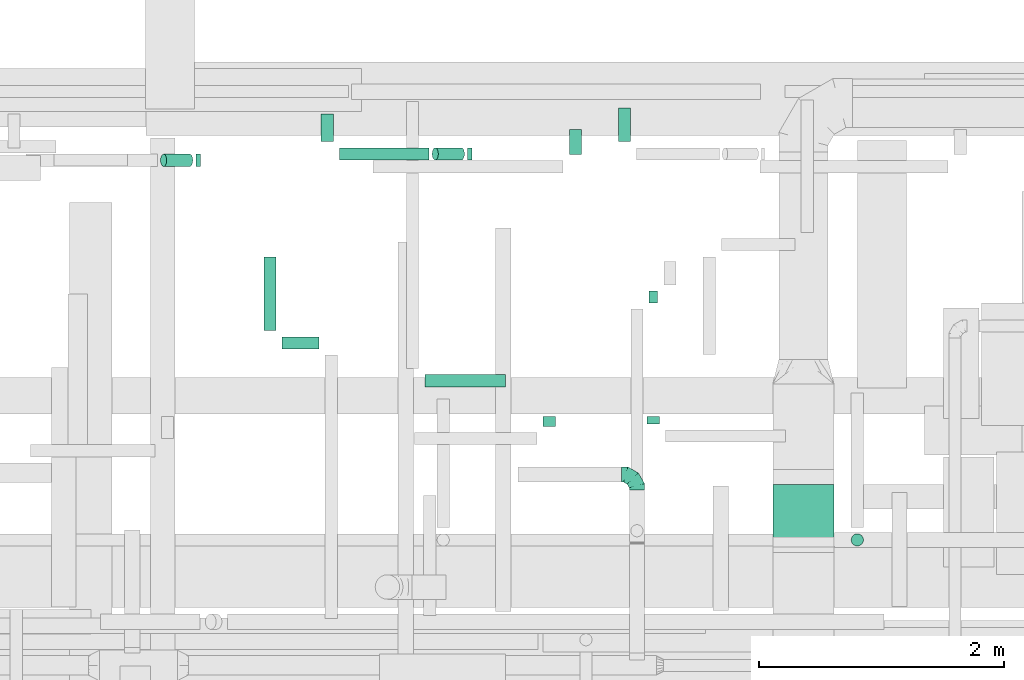
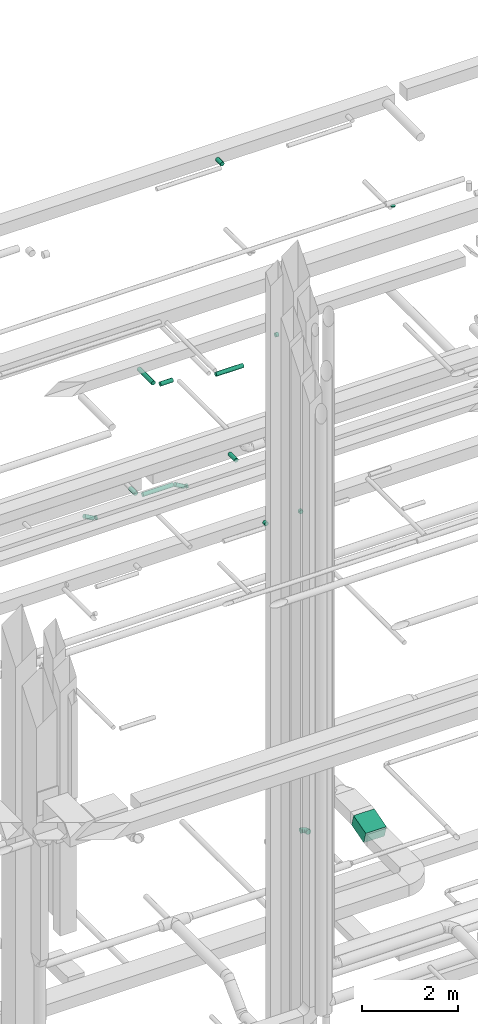
# One storey, part 156 of 337: 16 flow segments, 1 flow fitting.
"""IFC2X3 building model written with IfcOpenShell, lengths in millimetres."""

from ifc_helpers import new_model, entity, si_unit, converted_unit, derived_unit, direction, frame, frame_2d, origin, origin_2d_with_axis, place, context, subcontext, project, spatial, rectangle, circle, extrude, faceted_brep, source, transform, mapped, material, type_object, type_shapes, element, save


model = new_model("IFC2X3")

# Units and contexts
model_context = context("Model", 3, precision=0.01, world=origin(), true_north=direction((6.12303176911189e-17, 1.0)))
body_context = subcontext(model_context, "Body", "Model", "MODEL_VIEW")
ifc_project = project(units=[si_unit("LENGTHUNIT", "METRE", prefix="MILLI"), si_unit("AREAUNIT", "SQUARE_METRE"), si_unit("VOLUMEUNIT", "CUBIC_METRE"), converted_unit("PLANEANGLEUNIT", "DEGREE", entity("IfcRatioMeasure", 0.0174532925199433), si_unit("PLANEANGLEUNIT", "RADIAN"), dimensions=[0, 0, 0, 0, 0, 0, 0]), si_unit("MASSUNIT", "GRAM", prefix="KILO"), derived_unit("MASSDENSITYUNIT", [(si_unit("MASSUNIT", "GRAM", prefix="KILO"), 1), (si_unit("LENGTHUNIT", "METRE"), -3)]), derived_unit("MOMENTOFINERTIAUNIT", [(si_unit("LENGTHUNIT", "METRE"), 4)]), si_unit("TIMEUNIT", "SECOND"), si_unit("FREQUENCYUNIT", "HERTZ"), si_unit("THERMODYNAMICTEMPERATUREUNIT", "DEGREE_CELSIUS"), derived_unit("THERMALTRANSMITTANCEUNIT", [(si_unit("MASSUNIT", "GRAM", prefix="KILO"), 1), (si_unit("THERMODYNAMICTEMPERATUREUNIT", "KELVIN"), -1), (si_unit("TIMEUNIT", "SECOND"), -3)]), derived_unit("VOLUMETRICFLOWRATEUNIT", [(si_unit("LENGTHUNIT", "METRE"), 3), (si_unit("TIMEUNIT", "SECOND"), -1)]), derived_unit("MASSFLOWRATEUNIT", [(si_unit("MASSUNIT", "GRAM", prefix="KILO"), 1), (si_unit("TIMEUNIT", "SECOND"), -1)]), derived_unit("ROTATIONALFREQUENCYUNIT", [(si_unit("TIMEUNIT", "SECOND"), -1)]), si_unit("ELECTRICCURRENTUNIT", "AMPERE"), si_unit("ELECTRICVOLTAGEUNIT", "VOLT"), si_unit("POWERUNIT", "WATT"), si_unit("FORCEUNIT", "NEWTON", prefix="KILO"), si_unit("ILLUMINANCEUNIT", "LUX"), si_unit("LUMINOUSFLUXUNIT", "LUMEN"), si_unit("LUMINOUSINTENSITYUNIT", "CANDELA"), derived_unit("USERDEFINED", [(si_unit("MASSUNIT", "GRAM", prefix="KILO"), -1), (si_unit("LENGTHUNIT", "METRE"), -2), (si_unit("TIMEUNIT", "SECOND"), 3), (si_unit("LUMINOUSFLUXUNIT", "LUMEN"), 1)]), derived_unit("LINEARVELOCITYUNIT", [(si_unit("LENGTHUNIT", "METRE"), 1), (si_unit("TIMEUNIT", "SECOND"), -1)]), si_unit("PRESSUREUNIT", "PASCAL"), derived_unit("USERDEFINED", [(si_unit("LENGTHUNIT", "METRE"), -2), (si_unit("MASSUNIT", "GRAM", prefix="KILO"), 1), (si_unit("TIMEUNIT", "SECOND"), -2)]), derived_unit("LINEARFORCEUNIT", [(si_unit("MASSUNIT", "GRAM", prefix="KILO"), 1), (si_unit("LENGTHUNIT", "METRE"), 1), (si_unit("TIMEUNIT", "SECOND"), -2), (si_unit("LENGTHUNIT", "METRE"), -1)]), derived_unit("PLANARFORCEUNIT", [(si_unit("MASSUNIT", "GRAM", prefix="KILO"), 1), (si_unit("LENGTHUNIT", "METRE"), 1), (si_unit("TIMEUNIT", "SECOND"), -2), (si_unit("LENGTHUNIT", "METRE"), -2)])], contexts=[model_context])

# Site, building, storey
site_placement = place(None, origin())
site = spatial("IfcSite", under=ifc_project, at=site_placement, CompositionType="ELEMENT")
building_placement = place(site_placement, origin())
building = spatial("IfcBuilding", under=site, at=building_placement, CompositionType="ELEMENT")
storey_placement = place(building_placement, origin())
storey = spatial("IfcBuildingStorey", under=building, at=storey_placement, CompositionType="ELEMENT", Elevation=0.0)

# Flow segments
duct_segment_type_1 = type_object("IfcDuctSegmentType", PredefinedType="NOTDEFINED")
flow_segment_1_placement = place(storey_placement, frame((35072.98, 16190.58, 3167.41)))
element("IfcFlowSegment", 1, at=flow_segment_1_placement, inside=storey, type_object=duct_segment_type_1, context=body_context, shape_type="SweptSolid", body=[
    extrude(rectangle(XDim=300.000000000001, YDim=532.871032520621, at=frame_2d((0.0, 0.0), x_axis=(0.0, 1.0))), frame((0.0, 297.45, 217.59), z_axis=(1.0, 0.0, 0.0), x_axis=(0.0, 0.961311369016306, 0.275464066259097)), (0.0, 0.0, 1.0), 499.999999999999),
])
duct_segment_type_2 = type_object("IfcDuctSegmentType", PredefinedType="NOTDEFINED")
flow_segment_2_placement = place(storey_placement, frame((31531.43, 19353.19, 11348.4)))
element("IfcFlowSegment", 2, at=flow_segment_2_placement, inside=storey, type_object=duct_segment_type_2, context=body_context, shape_type="SweptSolid", body=[
    extrude(circle(Radius=50.0, at=origin_2d_with_axis()), frame((0.0, 51.6, 51.6), z_axis=(1.0, 0.0, 0.0), x_axis=(0.0, 1.0, 0.0)), (0.0, 0.0, 1.0), 733.205080756914),
])
flow_segment_3_placement = place(storey_placement, frame((32288.04, 19353.19, 11218.5)))
element("IfcFlowSegment", 3, at=flow_segment_3_placement, inside=storey, type_object=duct_segment_type_2, context=body_context, shape_type="SweptSolid", body=[
    extrude(circle(Radius=50.0, at=origin_2d_with_axis()), frame((239.99, 51.6, 44.9), z_axis=(-0.866025403784436, 0.0, 0.500000000000004), x_axis=(0.0, -1.0, 0.0)), (0.0, 0.0, 1.0), 246.410161513847),
])
flow_segment_4_placement = place(storey_placement, frame((32578.03, 19353.19, 11198.4)))
element("IfcFlowSegment", 4, at=flow_segment_4_placement, inside=storey, type_object=duct_segment_type_2, context=body_context, shape_type="SweptSolid", body=[
    extrude(circle(Radius=50.0, at=origin_2d_with_axis()), frame((0.0, 51.6, 51.6), z_axis=(1.0, 0.0, 0.0), x_axis=(0.0, -1.0, 0.0)), (0.0, 0.0, 1.0), 38.5640646055133),
])
flow_segment_5_placement = place(storey_placement, frame((31063.3, 17808.7, 15273.4)))
element("IfcFlowSegment", 5, at=flow_segment_5_placement, inside=storey, type_object=duct_segment_type_2, context=body_context, shape_type="SweptSolid", body=[
    extrude(circle(Radius=50.0, at=origin_2d_with_axis()), frame((0.0, 51.6, 51.6), z_axis=(1.0, 0.0, 0.0), x_axis=(0.0, 1.0, 0.0)), (0.0, 0.0, 1.0), 300.883890000033),
])
flow_segment_6_placement = place(storey_placement, frame((30911.7, 17960.29, 15273.4)))
element("IfcFlowSegment", 6, at=flow_segment_6_placement, inside=storey, type_object=duct_segment_type_2, context=body_context, shape_type="SweptSolid", body=[
    extrude(circle(Radius=50.0, at=origin_2d_with_axis()), frame((51.6, 0.0, 51.6), z_axis=(0.0, 1.0, 0.0), x_axis=(1.0, 0.0, 0.0)), (0.0, 0.0, 1.0), 600.561760586738),
])
flow_segment_7_placement = place(storey_placement, frame((34062.51, 18183.91, 15248.4)))
element("IfcFlowSegment", 7, at=flow_segment_7_placement, inside=storey, type_object=duct_segment_type_2, context=body_context, shape_type="SweptSolid", body=[
    extrude(circle(Radius=50.0, at=origin_2d_with_axis()), frame((0.0, 51.6, 51.6), z_axis=(1.0, 0.0, 0.0), x_axis=(0.0, -1.0, 0.0)), (0.0, 0.0, 1.0), 69.3149745718085),
])
flow_segment_8_placement = place(storey_placement, frame((30068.04, 19300.97, 11218.5)))
element("IfcFlowSegment", 8, at=flow_segment_8_placement, inside=storey, type_object=duct_segment_type_2, context=body_context, shape_type="SweptSolid", body=[
    extrude(circle(Radius=50.0, at=origin_2d_with_axis()), frame((26.6, 51.6, 168.1), z_axis=(0.866025403784436, 0.0, -0.500000000000004), x_axis=(0.0, -1.0, 0.0)), (0.0, 0.0, 1.0), 246.410161513847),
])
flow_segment_9_placement = place(storey_placement, frame((30358.03, 19300.97, 11198.4)))
element("IfcFlowSegment", 9, at=flow_segment_9_placement, inside=storey, type_object=duct_segment_type_2, context=body_context, shape_type="SweptSolid", body=[
    extrude(circle(Radius=50.0, at=origin_2d_with_axis()), frame((0.0, 51.6, 51.6), z_axis=(1.0, 0.0, 0.0), x_axis=(0.0, -1.0, 0.0)), (0.0, 0.0, 1.0), 38.564064605509),
])
flow_segment_10_placement = place(storey_placement, frame((33193.9, 17179.24, 11348.4)))
element("IfcFlowSegment", 10, at=flow_segment_10_placement, inside=storey, type_object=duct_segment_type_2, context=body_context, shape_type="SweptSolid", body=[
    extrude(circle(Radius=50.0, at=origin_2d_with_axis()), frame((51.6, 0.0, 51.6), z_axis=(0.0, 1.0, 0.0), x_axis=(1.0, 0.0, 0.0)), (0.0, 0.0, 1.0), 78.9450171079088),
])
flow_segment_11_placement = place(storey_placement, frame((34043.82, 17199.24, 11348.4)))
element("IfcFlowSegment", 11, at=flow_segment_11_placement, inside=storey, type_object=duct_segment_type_2, context=body_context, shape_type="SweptSolid", body=[
    extrude(circle(Radius=50.0, at=origin_2d_with_axis()), frame((51.6, 0.0, 51.6), z_axis=(0.0, 1.0, 0.0), x_axis=(1.0, 0.0, 0.0)), (0.0, 0.0, 1.0), 58.9376194575211),
])
flow_segment_12_placement = place(storey_placement, frame((31379.83, 19504.79, 11348.4)))
element("IfcFlowSegment", 12, at=flow_segment_12_placement, inside=storey, type_object=duct_segment_type_2, context=body_context, shape_type="SweptSolid", body=[
    extrude(circle(Radius=50.0, at=origin_2d_with_axis()), frame((51.6, 0.0, 51.6), z_axis=(0.0, 1.0, 0.0), x_axis=(1.0, 0.0, 0.0)), (0.0, 0.0, 1.0), 226.269796034465),
])
flow_segment_13_placement = place(storey_placement, frame((33809.29, 19504.79, 11348.4)))
element("IfcFlowSegment", 13, at=flow_segment_13_placement, inside=storey, type_object=duct_segment_type_2, context=body_context, shape_type="SweptSolid", body=[
    extrude(circle(Radius=50.0, at=origin_2d_with_axis()), frame((51.6, 0.0, 51.6), z_axis=(0.0, 1.0, 0.0), x_axis=(1.0, 0.0, 0.0)), (0.0, 0.0, 1.0), 276.269796034389),
])
flow_segment_14_placement = place(storey_placement, frame((33408.45, 19399.86, 19118.4)))
element("IfcFlowSegment", 14, at=flow_segment_14_placement, inside=storey, type_object=duct_segment_type_2, context=body_context, shape_type="SweptSolid", body=[
    extrude(circle(Radius=50.0, at=origin_2d_with_axis()), frame((51.6, 0.0, 51.6), z_axis=(0.0, 1.0, 0.0), x_axis=(1.0, 0.0, 0.0)), (0.0, 0.0, 1.0), 205.46874999999),
])
flow_segment_15_placement = place(storey_placement, frame((35711.99, 16198.76, 19200.0)))
element("IfcFlowSegment", 15, at=flow_segment_15_placement, inside=storey, type_object=duct_segment_type_2, context=body_context, shape_type="SweptSolid", body=[
    extrude(circle(Radius=50.0, at=origin_2d_with_axis()), frame((51.6, 51.6, 0.0)), (0.0, 0.0, 1.0), 17.499999999983),
])
flow_segment_16_placement = place(storey_placement, frame((32229.04, 17499.79, 15298.4)))
element("IfcFlowSegment", 16, at=flow_segment_16_placement, inside=storey, type_object=duct_segment_type_2, context=body_context, shape_type="SweptSolid", body=[
    extrude(circle(Radius=50.0, at=origin_2d_with_axis()), frame((0.0, 51.6, 51.6), z_axis=(1.0, 0.0, 0.0), x_axis=(0.0, -1.0, 0.0)), (0.0, 0.0, 1.0), 660.00000000001),
])

# Flow fitting
ifc_material = material()
duct_fitting_type = type_object("IfcDuctFittingType", PredefinedType="NOTDEFINED", material=ifc_material)
shared_shape = source(origin(), body_context, "Body", "Brep", [
    faceted_brep([(-125.0, 0.0, -62.5), (-125.0, -16.18, -60.37), (-125.0, -31.25, -54.13), (-125.0, -44.19, -44.19), (-125.0, -54.13, -31.25), (-125.0, -60.37, -16.18), (-125.0, -62.5, 0.0), (-125.0, -60.37, 16.18), (-125.0, -54.13, 31.25), (-125.0, -44.19, 44.19), (-125.0, -31.25, 54.13), (-125.0, -16.18, 60.37), (-125.0, 0.0, 62.5), (-125.0, 16.18, 60.37), (-125.0, 31.25, 54.13), (-125.0, 44.19, 44.19), (-125.0, 54.13, 31.25), (-125.0, 60.37, 16.18), (-125.0, 62.5, 0.0), (-125.0, 60.37, -16.18), (-125.0, 54.13, -31.25), (-125.0, 44.19, -44.19), (-125.0, 31.25, -54.13), (-125.0, 16.18, -60.37), (-95.84, 16.18, 60.37), (-99.88, 31.25, 54.13), (-91.51, 0.0, 62.5), (-103.35, 44.19, 44.19), (-107.68, 60.37, 16.18), (-108.25, 62.5, 0.0), (-106.01, 54.13, 31.25), (-106.01, 54.13, -31.25), (-103.35, 44.19, -44.19), (-107.68, 60.37, -16.18), (-95.84, 16.18, -60.37), (-91.51, 0.0, -62.5), (-99.88, 31.25, -54.13), (-87.17, -16.18, -60.37), (-83.13, -31.25, -54.13), (-79.66, -44.19, -44.19), (-77.0, -54.13, -31.25), (-75.33, -60.37, -16.18), (-74.76, -62.5, 0.0), (-75.33, -60.37, 16.18), (-77.0, -54.13, 31.25), (-79.66, -44.19, 44.19), (-83.13, -31.25, 54.13), (-87.17, -16.18, 60.37), (-45.34, 45.34, 60.37), (-56.37, 56.37, 54.13), (-33.49, 33.49, 62.5), (-65.85, 65.85, 44.19), (-73.12, 73.12, 31.25), (-77.69, 77.69, 16.18), (-79.25, 79.25, 0.0), (-77.69, 77.69, -16.18), (-73.12, 73.12, -31.25), (-65.85, 65.85, -44.19), (-45.34, 45.34, -60.37), (-33.49, 33.49, -62.5), (-56.37, 56.37, -54.13), (-21.65, 21.65, -60.37), (-10.62, 10.62, -54.13), (-1.14, 1.14, -44.19), (6.13, -6.13, -31.25), (10.7, -10.7, -16.18), (12.26, -12.26, 0.0), (10.7, -10.7, 16.18), (6.13, -6.13, 31.25), (-1.14, 1.14, 44.19), (-10.62, 10.62, 54.13), (-21.65, 21.65, 60.37), (-16.18, 95.84, 60.37), (-31.25, 99.88, 54.13), (0.0, 91.51, 62.5), (-44.19, 103.35, 44.19), (-54.13, 106.01, 31.25), (-60.37, 107.68, 16.18), (-62.5, 108.25, 0.0), (-60.37, 107.68, -16.18), (-54.13, 106.01, -31.25), (-44.19, 103.35, -44.19), (-16.18, 95.84, -60.37), (0.0, 91.51, -62.5), (-31.25, 99.88, -54.13), (16.18, 87.17, -60.37), (31.25, 83.13, -54.13), (44.19, 79.66, -44.19), (54.13, 77.0, -31.25), (60.37, 75.33, -16.18), (62.5, 74.76, 0.0), (60.37, 75.33, 16.18), (54.13, 77.0, 31.25), (44.19, 79.66, 44.19), (31.25, 83.13, 54.13), (16.18, 87.17, 60.37), (-16.18, 125.0, -60.37), (-31.25, 125.0, -54.13), (-44.19, 125.0, -44.19), (-54.13, 125.0, -31.25), (-60.37, 125.0, -16.18), (-62.5, 125.0, 0.0), (-60.37, 125.0, 16.18), (-54.13, 125.0, 31.25), (-44.19, 125.0, 44.19), (-31.25, 125.0, 54.13), (-16.18, 125.0, 60.37), (0.0, 125.0, 62.5), (16.18, 125.0, 60.37), (31.25, 125.0, 54.13), (44.19, 125.0, 44.19), (54.13, 125.0, 31.25), (60.37, 125.0, 16.18), (62.5, 125.0, 0.0), (60.37, 125.0, -16.18), (54.13, 125.0, -31.25), (44.19, 125.0, -44.19), (31.25, 125.0, -54.13), (16.18, 125.0, -60.37), (0.0, 125.0, -62.5)], [[[0, 1, 2, 3, 4, 5, 6, 7, 8, 9, 10, 11, 12, 13, 14, 15, 16, 17, 18, 19, 20, 21, 22, 23]], [[24, 25, 14, 13]], [[26, 24, 13, 12]], [[14, 25, 27, 15]], [[28, 29, 18, 17]], [[30, 28, 17, 16]], [[15, 27, 30, 16]], [[20, 31, 32, 21]], [[33, 31, 20, 19]], [[18, 29, 33, 19]], [[34, 35, 0, 23]], [[36, 34, 23, 22]], [[21, 32, 36, 22]], [[1, 0, 35, 37]], [[2, 1, 37, 38]], [[38, 39, 3, 2]], [[5, 4, 40, 41]], [[6, 5, 41, 42]], [[39, 40, 4, 3]], [[6, 42, 43, 7]], [[7, 43, 44, 8]], [[45, 9, 8, 44]], [[9, 45, 46, 10]], [[10, 46, 47, 11]], [[26, 12, 11, 47]], [[48, 49, 25, 24]], [[50, 48, 24, 26]], [[27, 25, 49, 51]], [[52, 53, 28, 30]], [[51, 52, 30, 27]], [[29, 28, 53, 54]], [[55, 56, 31, 33]], [[54, 55, 33, 29]], [[57, 32, 31, 56]], [[58, 59, 35, 34]], [[60, 58, 34, 36]], [[57, 60, 36, 32]], [[37, 35, 59, 61]], [[38, 37, 61, 62]], [[39, 38, 62, 63]], [[41, 40, 64, 65]], [[42, 41, 65, 66]], [[63, 64, 40, 39]], [[43, 42, 66, 67]], [[44, 43, 67, 68]], [[68, 69, 45, 44]], [[46, 45, 69, 70]], [[47, 46, 70, 71]], [[26, 47, 71, 50]], [[72, 73, 49, 48]], [[74, 72, 48, 50]], [[51, 49, 73, 75]], [[76, 77, 53, 52]], [[75, 76, 52, 51]], [[54, 53, 77, 78]], [[79, 80, 56, 55]], [[78, 79, 55, 54]], [[81, 57, 56, 80]], [[82, 83, 59, 58]], [[84, 82, 58, 60]], [[81, 84, 60, 57]], [[61, 59, 83, 85]], [[62, 61, 85, 86]], [[63, 62, 86, 87]], [[65, 64, 88, 89]], [[66, 65, 89, 90]], [[87, 88, 64, 63]], [[67, 66, 90, 91]], [[68, 67, 91, 92]], [[92, 93, 69, 68]], [[70, 69, 93, 94]], [[71, 70, 94, 95]], [[50, 71, 95, 74]], [[96, 97, 98, 99, 100, 101, 102, 103, 104, 105, 106, 107, 108, 109, 110, 111, 112, 113, 114, 115, 116, 117, 118, 119]], [[72, 74, 107, 106]], [[73, 72, 106, 105]], [[75, 73, 105, 104]], [[77, 76, 103, 102]], [[78, 77, 102, 101]], [[75, 104, 103, 76]], [[78, 101, 100, 79]], [[79, 100, 99, 80]], [[80, 99, 98, 81]], [[96, 119, 83, 82]], [[97, 96, 82, 84]], [[84, 81, 98, 97]], [[83, 119, 118, 85]], [[85, 118, 117, 86]], [[116, 87, 86, 117]], [[88, 115, 114, 89]], [[89, 114, 113, 90]], [[115, 88, 87, 116]], [[91, 90, 113, 112]], [[92, 91, 112, 111]], [[111, 110, 93, 92]], [[95, 94, 109, 108]], [[74, 95, 108, 107]], [[110, 109, 94, 93]]]),
])
type_shapes(duct_fitting_type, [shared_shape])
flow_fitting_placement = place(storey_placement, frame((33962.52, 16784.94, 3600.0), z_axis=(0.0, 0.0, 1.0), x_axis=(0.0, 1.0, 0.0)))
element("IfcFlowFitting", 17, at=flow_fitting_placement, inside=storey, type_object=duct_fitting_type, material=ifc_material, context=body_context, shape_type="MappedRepresentation", body=[
    mapped(shared_shape, transform((0.0, 0.0, 0.0), scale=1.0)),
])

save(model, "model.ifc")
